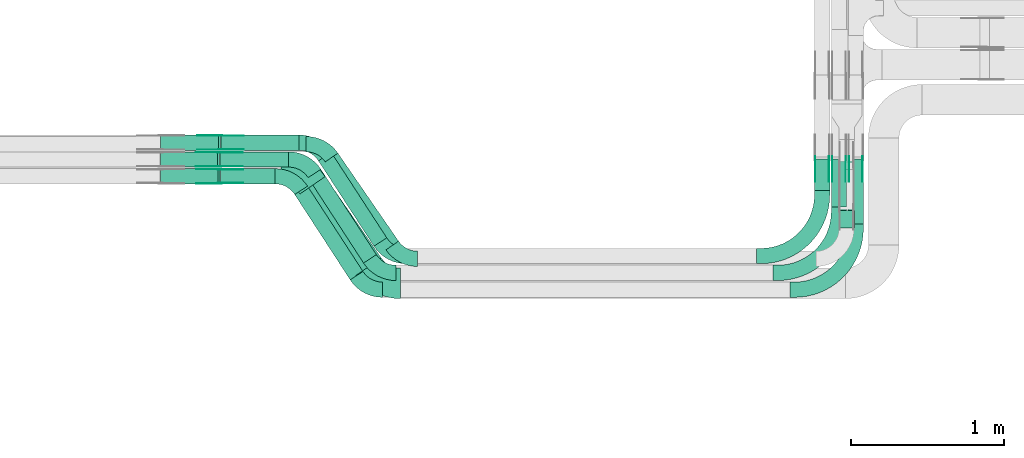
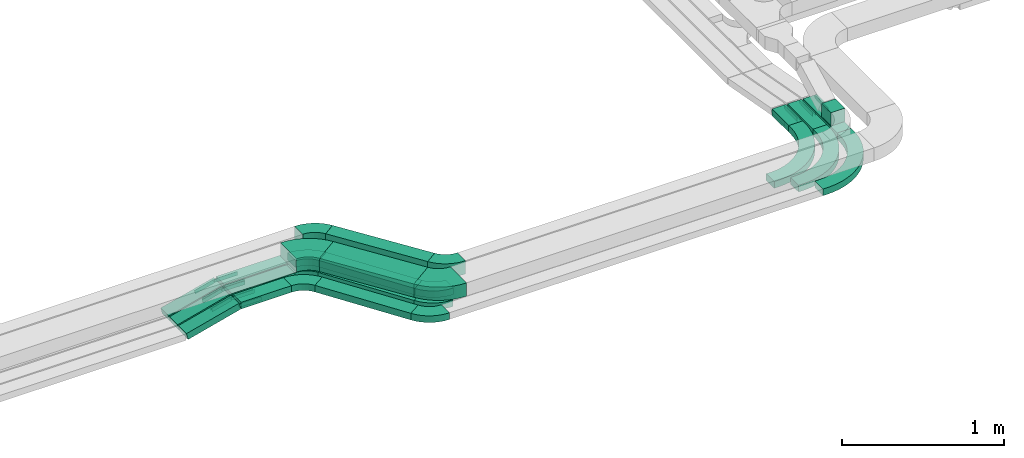
# One storey, part 9 of 25: 31 flow fittings, 15 flow segments.
"""IFC2X3 building model written with IfcOpenShell, lengths in millimetres."""

from ifc_helpers import new_model, entity, si_unit, converted_unit, derived_unit, direction, frame, frame_2d, origin, origin_2d_with_axis, place, context, subcontext, project, spatial, polyline, circle_curve, parameter, trimmed, segment, composite_curve, rectangle, outline, extrude, source, transform, mapped, material, type_object, type_shapes, element, save


model = new_model("IFC2X3")

# Units and contexts
model_context = context("Model", 3, precision=0.01, world=origin(), true_north=direction((6.12303176911189e-17, 1.0)))
body_context = subcontext(model_context, "Body", "Model", "MODEL_VIEW")
ifc_project = project(units=[si_unit("LENGTHUNIT", "METRE", prefix="MILLI"), si_unit("AREAUNIT", "SQUARE_METRE"), si_unit("VOLUMEUNIT", "CUBIC_METRE"), converted_unit("PLANEANGLEUNIT", "DEGREE", entity("IfcRatioMeasure", 0.0174532925199433), si_unit("PLANEANGLEUNIT", "RADIAN"), dimensions=[0, 0, 0, 0, 0, 0, 0]), si_unit("MASSUNIT", "GRAM", prefix="KILO"), derived_unit("MASSDENSITYUNIT", [(si_unit("MASSUNIT", "GRAM", prefix="KILO"), 1), (si_unit("LENGTHUNIT", "METRE"), -3)]), derived_unit("MOMENTOFINERTIAUNIT", [(si_unit("LENGTHUNIT", "METRE"), 4)]), si_unit("TIMEUNIT", "SECOND"), si_unit("FREQUENCYUNIT", "HERTZ"), si_unit("THERMODYNAMICTEMPERATUREUNIT", "DEGREE_CELSIUS"), derived_unit("THERMALTRANSMITTANCEUNIT", [(si_unit("MASSUNIT", "GRAM", prefix="KILO"), 1), (si_unit("THERMODYNAMICTEMPERATUREUNIT", "KELVIN"), -1), (si_unit("TIMEUNIT", "SECOND"), -3)]), derived_unit("VOLUMETRICFLOWRATEUNIT", [(si_unit("LENGTHUNIT", "METRE"), 3), (si_unit("TIMEUNIT", "SECOND"), -1)]), derived_unit("MASSFLOWRATEUNIT", [(si_unit("MASSUNIT", "GRAM", prefix="KILO"), 1), (si_unit("TIMEUNIT", "SECOND"), -1)]), derived_unit("ROTATIONALFREQUENCYUNIT", [(si_unit("TIMEUNIT", "SECOND"), -1)]), si_unit("ELECTRICCURRENTUNIT", "AMPERE"), si_unit("ELECTRICVOLTAGEUNIT", "VOLT"), si_unit("POWERUNIT", "WATT"), si_unit("FORCEUNIT", "NEWTON", prefix="KILO"), si_unit("ILLUMINANCEUNIT", "LUX"), si_unit("LUMINOUSFLUXUNIT", "LUMEN"), si_unit("LUMINOUSINTENSITYUNIT", "CANDELA"), derived_unit("USERDEFINED", [(si_unit("MASSUNIT", "GRAM", prefix="KILO"), -1), (si_unit("LENGTHUNIT", "METRE"), -2), (si_unit("TIMEUNIT", "SECOND"), 3), (si_unit("LUMINOUSFLUXUNIT", "LUMEN"), 1)]), derived_unit("LINEARVELOCITYUNIT", [(si_unit("LENGTHUNIT", "METRE"), 1), (si_unit("TIMEUNIT", "SECOND"), -1)]), si_unit("PRESSUREUNIT", "PASCAL"), derived_unit("USERDEFINED", [(si_unit("LENGTHUNIT", "METRE"), -2), (si_unit("MASSUNIT", "GRAM", prefix="KILO"), 1), (si_unit("TIMEUNIT", "SECOND"), -2)]), derived_unit("LINEARFORCEUNIT", [(si_unit("MASSUNIT", "GRAM", prefix="KILO"), 1), (si_unit("LENGTHUNIT", "METRE"), 1), (si_unit("TIMEUNIT", "SECOND"), -2), (si_unit("LENGTHUNIT", "METRE"), -1)]), derived_unit("PLANARFORCEUNIT", [(si_unit("MASSUNIT", "GRAM", prefix="KILO"), 1), (si_unit("LENGTHUNIT", "METRE"), 1), (si_unit("TIMEUNIT", "SECOND"), -2), (si_unit("LENGTHUNIT", "METRE"), -2)])], contexts=[model_context])

# Site, building, storey
site_placement = place(None, frame((0.0, -0.00077364408347762, 0.0)))
site = spatial("IfcSite", under=ifc_project, at=site_placement, CompositionType="ELEMENT")
building_placement = place(site_placement, origin())
building = spatial("IfcBuilding", under=site, at=building_placement, CompositionType="ELEMENT")
storey_placement = place(building_placement, frame((0.0, 0.0, 24000.0)))
storey = spatial("IfcBuildingStorey", under=building, at=storey_placement, CompositionType="ELEMENT", Elevation=24000.0)

# Flow segments
cable_carrier_segment_type = type_object("IfcCableCarrierSegmentType", PredefinedType="CABLETRAYSEGMENT")
flow_segment_1_placement = place(storey_placement, frame((28945.0794468743, 10007.8235639286, 2749.99997416677)))
element("IfcFlowSegment", 1, at=flow_segment_1_placement, inside=storey, type_object=cable_carrier_segment_type, context=body_context, shape_type="SweptSolid", body=[
    extrude(rectangle(XDim=449.703961054591, YDim=99.9999999999989, at=frame_2d((-2.17426077142591e-12, 0.0), x_axis=(1.0, 0.0))), frame((224.851983399546, 50.0, 1.2916621039949e-05)), (0.0, 0.0, 1.0), 49.9999999999931),
])
flow_segment_2_placement = place(storey_placement, frame((28952.8892089489, 10117.8235639283, 2749.99997093508)))
element("IfcFlowSegment", 2, at=flow_segment_2_placement, inside=storey, type_object=cable_carrier_segment_type, context=body_context, shape_type="SweptSolid", body=[
    extrude(rectangle(XDim=509.777434753036, YDim=99.9999999999989, at=frame_2d((-2.17426077142591e-12, -1.08357767203415e-12), x_axis=(1.0, 0.0))), frame((254.888720227263, 50.0, 1.45324623758825e-05)), (0.0, 0.0, 1.0), 49.9999999999974),
])
flow_segment_3_placement = place(storey_placement, frame((29589.9781757951, 9490.69919240016, 2750.0)))
element("IfcFlowSegment", 3, at=flow_segment_3_placement, inside=storey, type_object=cable_carrier_segment_type, context=body_context, shape_type="SweptSolid", body=[
    extrude(rectangle(XDim=665.559579029172, YDim=100.000000000004, at=origin_2d_with_axis()), frame((223.283289414054, 306.266508075534, 3.12262928900964e-06), z_axis=(5.11388203057767e-09, -7.86751081627487e-09, 1.0), x_axis=(0.544988350595341, -0.838443616300685, -9.38347035306593e-09)), (0.0, 0.0, 1.0), 49.9999999999973),
])
flow_segment_4_placement = place(storey_placement, frame((29634.4910697948, 9466.72606910952, 2890.0)))
element("IfcFlowSegment", 4, at=flow_segment_4_placement, inside=storey, type_object=cable_carrier_segment_type, context=body_context, shape_type="SweptSolid", body=[
    extrude(rectangle(XDim=698.971890855876, YDim=99.9999999999974, at=frame_2d((2.58637555816676e-12, 8.5265128291212e-13), x_axis=(1.0, 0.0))), frame((239.55958163975, 316.097494713159, 0.0), z_axis=(0.0, 0.0, 1.0), x_axis=(0.567682967884993, -0.823247258102501, 0.0)), (0.0, 0.0, 1.0), 100.000000000003),
])
flow_segment_5_placement = place(storey_placement, frame((28948.3109912879, 9897.82356392861, 2749.99997910151)))
element("IfcFlowSegment", 5, at=flow_segment_5_placement, inside=storey, type_object=cable_carrier_segment_type, context=body_context, shape_type="SweptSolid", body=[
    extrude(rectangle(XDim=359.081105196311, YDim=99.9999999999989, at=origin_2d_with_axis()), frame((179.540555508148, 50.0, 1.04492476452833e-05)), (0.0, 0.0, 1.0), 49.9999999999974),
])
flow_segment_6_placement = place(storey_placement, frame((29469.0115403312, 9299.95777232105, 2890.0)))
element("IfcFlowSegment", 6, at=flow_segment_6_placement, inside=storey, type_object=cable_carrier_segment_type, context=body_context, shape_type="SweptSolid", body=[
    extrude(rectangle(XDim=646.458259275562, YDim=199.999999999999, at=frame_2d((2.1316282072803e-12, 1.15818465928896e-12), x_axis=(1.0, 0.0))), frame((265.8163974299, 322.865791501663, 0.0), z_axis=(0.0, 0.0, 1.0), x_axis=(0.567682967884968, -0.823247258102519, 0.0)), (0.0, 0.0, 1.0), 100.000000000003),
])
flow_segment_7_placement = place(storey_placement, frame((29434.7036286044, 9270.69919239606, 2750.0)))
element("IfcFlowSegment", 7, at=flow_segment_7_placement, inside=storey, type_object=cable_carrier_segment_type, context=body_context, shape_type="SweptSolid", body=[
    extrude(rectangle(XDim=665.559579029205, YDim=99.9999999999987, at=frame_2d((1.90425453183707e-12, 3.93640675611096e-12), x_axis=(1.0, 0.0))), frame((223.283289414063, 306.266508083721, 3.18753634473978e-06), z_axis=(5.22016867856222e-09, -8.03102873625081e-09, 1.0), x_axis=(0.544988350595353, -0.838443616300677, -9.57849589419594e-09)), (0.0, 0.0, 1.0), 50.0000000000016),
])
flow_segment_8_placement = place(storey_placement, frame((29522.0949400319, 9380.69919239868, 2750.0)))
element("IfcFlowSegment", 8, at=flow_segment_8_placement, inside=storey, type_object=cable_carrier_segment_type, context=body_context, shape_type="SweptSolid", body=[
    extrude(rectangle(XDim=665.559579029195, YDim=99.9999999999999, at=frame_2d((9.09494701772928e-13, -5.82645043323282e-13), x_axis=(1.0, 0.0))), frame((223.283289414063, 306.266508078508, 3.14618381480614e-06), z_axis=(5.15245691573413e-09, -7.9268567934381e-09, 1.0), x_axis=(0.544988350595368, -0.838443616300667, -9.4542514718074e-09)), (0.0, 0.0, 1.0), 49.9999999999973),
])
flow_segment_9_placement = place(storey_placement, frame((28557.66472809, 9897.82356393049, 2651.99307910285)))
element("IfcFlowSegment", 9, at=flow_segment_9_placement, inside=storey, type_object=cable_carrier_segment_type, context=body_context, shape_type="SweptSolid", body=[
    extrude(rectangle(XDim=49.9999999999986, YDim=99.9999999999989, at=origin_2d_with_axis()), frame((6.29726028523068, 50.0, 24.193894124344), z_axis=(0.967755764973787, 0.0, 0.251890411409408), x_axis=(-0.251890411409408, 0.0, 0.967755764973787)), (0.0, 0.0, 1.0), 387.573437364003),
])
flow_segment_10_placement = place(storey_placement, frame((28557.6416479044, 10007.8235639291, 2652.02409303392)))
element("IfcFlowSegment", 10, at=flow_segment_10_placement, inside=storey, type_object=cable_carrier_segment_type, context=body_context, shape_type="SweptSolid", body=[
    extrude(rectangle(XDim=49.9999999999973, YDim=99.9999999999989, at=origin_2d_with_axis()), frame((6.34769694242575, 50.0, 24.1807101534848), z_axis=(0.967228406139617, 0.0, 0.253907877697044), x_axis=(-0.253907877697044, 0.0, 0.967228406139617)), (0.0, 0.0, 1.0), 384.355490296213),
])
flow_segment_11_placement = place(storey_placement, frame((28557.6970734248, 10117.8235639283, 2651.95155380425)))
element("IfcFlowSegment", 11, at=flow_segment_11_placement, inside=storey, type_object=cable_carrier_segment_type, context=body_context, shape_type="SweptSolid", body=[
    extrude(rectangle(XDim=50.0000000000031, YDim=99.9999999999989, at=origin_2d_with_axis()), frame((6.22706032243303, 50.0, 24.2120573215265), z_axis=(0.968482292861, 0.0, 0.249082412897219), x_axis=(-0.249082412897219, 0.0, 0.968482292861)), (0.0, 0.0, 1.0), 392.132317558253),
])
flow_segment_12_placement = place(storey_placement, frame((33053.0827924389, 9636.10783662939, 2750.0)))
element("IfcFlowSegment", 12, at=flow_segment_12_placement, inside=storey, type_object=cable_carrier_segment_type, context=body_context, shape_type="SweptSolid", body=[
    extrude(rectangle(XDim=426.077042321789, YDim=100.000000000003, at=frame_2d((5.40012479177676e-13, 0.0), x_axis=(1.0, 0.0))), frame((50.0, 213.038521160895, 0.0), z_axis=(0.0, 0.0, 1.0), x_axis=(0.0, -1.0, 0.0)), (0.0, 0.0, 1.0), 49.9999999999973),
])
flow_segment_13_placement = place(storey_placement, frame((32943.0827924389, 9746.1078366294, 2750.0)))
element("IfcFlowSegment", 13, at=flow_segment_13_placement, inside=storey, type_object=cable_carrier_segment_type, context=body_context, shape_type="SweptSolid", body=[
    extrude(rectangle(XDim=316.077042321782, YDim=100.000000000003, at=origin_2d_with_axis()), frame((50.0, 158.038521160892, 0.0), z_axis=(0.0, 0.0, 1.0), x_axis=(0.0, 1.0, 0.0)), (0.0, 0.0, 1.0), 49.9999999999973),
])
flow_segment_14_placement = place(storey_placement, frame((32833.0827924389, 9856.10783662938, 2750.0)))
element("IfcFlowSegment", 14, at=flow_segment_14_placement, inside=storey, type_object=cable_carrier_segment_type, context=body_context, shape_type="SweptSolid", body=[
    extrude(rectangle(XDim=206.07704232179, YDim=100.000000000003, at=frame_2d((0.0, -2.16715534406831e-12), x_axis=(1.0, 0.0))), frame((50.0, 103.038521160898, 0.0), z_axis=(0.0, 0.0, 1.0), x_axis=(0.0, -1.0, 0.0)), (0.0, 0.0, 1.0), 49.9999999999973),
])
flow_segment_15_placement = place(storey_placement, frame((32993.082792439, 9608.82356382262, 2890.0)))
element("IfcFlowSegment", 15, at=flow_segment_15_placement, inside=storey, type_object=cable_carrier_segment_type, context=body_context, shape_type="SweptSolid", body=[
    extrude(rectangle(XDim=116.82449845036, YDim=100.000000000003, at=frame_2d((5.40012479177676e-13, 2.16715534406831e-12), x_axis=(1.0, 0.0))), frame((50.0, 58.4122492252194, 0.0), z_axis=(0.0, 0.0, 1.0), x_axis=(0.0, 1.0, 0.0)), (0.0, 0.0, 1.0), 100.000000000003),
])

# Flow fittings
ifc_material_1 = material(Name="G")
cable_carrier_fitting_type_1 = type_object("IfcCableCarrierFittingType", PredefinedType="NOTDEFINED", material=ifc_material_1)
shared_shape_1 = source(origin(), body_context, "Body", "SweptSolid", [
    extrude(outline(composite_curve([segment(trimmed(circle_curve(frame_2d((-44.5901162790698, 0.0), x_axis=(1.0, 0.0)), 12.5), [parameter(90.0000000000007)], [parameter(270.0)], True, "PARAMETER"), True, "CONTINUOUS"), segment(polyline([(-44.5901162790697, -12.5), (-33.0901162790698, -12.5)]), True, "CONTINUOUS"), segment(polyline([(-33.0901162790698, -12.5), (-31.2296511627907, -14.5)]), True, "CONTINUOUS"), segment(polyline([(-31.2296511627907, -14.5), (108.90988372093, -14.5)]), True, "CONTINUOUS"), segment(polyline([(108.90988372093, -14.5), (108.90988372093, 14.5)]), True, "CONTINUOUS"), segment(polyline([(108.90988372093, 14.5), (-31.2296511627907, 14.5)]), True, "CONTINUOUS"), segment(polyline([(-31.2296511627907, 14.5), (-33.0901162790698, 12.5)]), True, "CONTINUOUS"), segment(polyline([(-33.0901162790698, 12.5), (-44.5901162790699, 12.5)]), True, "CONTINUOUS")], self_intersect=False)), frame((44.5901162790698, 0.0, 0.0), z_axis=(0.0, 0.0, -1.0), x_axis=(1.0, 0.0, 0.0)), (0.0, 0.0, -1.0), 2.0),
])
type_shapes(cable_carrier_fitting_type_1, [shared_shape_1])
for number, where, z_axis, x_axis in (
    (16, (28943.5987331358, 9902.36356392033, 2774.99997882727), (0.0, -1.0, 0.0), (-0.96775576497502, 0.0, -0.251890411404671)),
    (17, (28940.336452955, 10012.3635639189, 2774.99997389431), (0.0, -1.0, 0.0), (-0.967228406140868, 0.0, -0.253907877692276)),
    (18, (28948.2196887602, 10122.3635639181, 2774.99997066886), (0.0, -1.0, 0.0), (-0.968482292862194, 0.0, -0.249082412892576)),
):
    element("IfcFlowFitting", number, at=place(storey_placement, frame(where, z_axis=z_axis, x_axis=x_axis)), inside=storey, type_object=cable_carrier_fitting_type_1, material=ifc_material_1, context=body_context, shape_type="MappedRepresentation", body=[
        mapped(shared_shape_1, transform((0.0, 0.0, 0.0), scale=1.0)),
    ])
cable_carrier_fitting_type_2 = type_object("IfcCableCarrierFittingType", PredefinedType="NOTDEFINED", material=ifc_material_1)
shared_shape_2 = source(origin(), body_context, "Body", "SweptSolid", [
    extrude(outline(composite_curve([segment(trimmed(circle_curve(frame_2d((-44.5901162790697, 0.0), x_axis=(1.0, 0.0)), 12.5), [parameter(90.0000000000007)], [parameter(270.0)], True, "PARAMETER"), True, "CONTINUOUS"), segment(polyline([(-44.5901162790697, -12.5), (-33.0901162790697, -12.5)]), True, "CONTINUOUS"), segment(polyline([(-33.0901162790697, -12.5), (-31.2296511627907, -14.5)]), True, "CONTINUOUS"), segment(polyline([(-31.2296511627907, -14.5), (108.90988372093, -14.5)]), True, "CONTINUOUS"), segment(polyline([(108.90988372093, -14.5), (108.90988372093, 14.5)]), True, "CONTINUOUS"), segment(polyline([(108.90988372093, 14.5), (-31.2296511627907, 14.5)]), True, "CONTINUOUS"), segment(polyline([(-31.2296511627907, 14.5), (-33.0901162790698, 12.5)]), True, "CONTINUOUS"), segment(polyline([(-33.0901162790698, 12.5), (-44.5901162790699, 12.5)]), True, "CONTINUOUS")], self_intersect=False)), frame((44.5901162790697, 0.0, 0.0)), (0.0, 0.0, 1.0), 2.0),
])
type_shapes(cable_carrier_fitting_type_2, [shared_shape_2])
for number, where, z_axis, x_axis in (
    (19, (28943.5987331358, 9993.28356394065, 2774.99997882727), (0.0, 1.0, 0.0), (-0.96775576497502, 0.0, -0.251890411404671)),
    (20, (28940.336452955, 10103.2835639393, 2774.99997389431), (0.0, 1.0, 0.0), (-0.967228406140868, 0.0, -0.253907877692276)),
    (21, (28948.2196887602, 10213.2835639385, 2774.99997066886), (0.0, 1.0, 0.0), (-0.968482292862194, 0.0, -0.249082412892576)),
):
    element("IfcFlowFitting", number, at=place(storey_placement, frame(where, z_axis=z_axis, x_axis=x_axis)), inside=storey, type_object=cable_carrier_fitting_type_2, material=ifc_material_1, context=body_context, shape_type="MappedRepresentation", body=[
        mapped(shared_shape_2, transform((0.0, 0.0, 0.0), scale=1.0)),
    ])
cable_carrier_fitting_type_3 = type_object("IfcCableCarrierFittingType", PredefinedType="NOTDEFINED", material=ifc_material_1)
shared_shape_3 = source(origin(), body_context, "Body", "SweptSolid", [
    extrude(outline(composite_curve([segment(trimmed(circle_curve(frame_2d((-44.5901162790698, 0.0), x_axis=(1.0, 0.0)), 12.5), [parameter(90.0000000000007)], [parameter(270.0)], True, "PARAMETER"), True, "CONTINUOUS"), segment(polyline([(-44.5901162790697, -12.5), (-33.0901162790698, -12.5)]), True, "CONTINUOUS"), segment(polyline([(-33.0901162790698, -12.5), (-31.2296511627907, -14.5)]), True, "CONTINUOUS"), segment(polyline([(-31.2296511627907, -14.5), (108.90988372093, -14.5)]), True, "CONTINUOUS"), segment(polyline([(108.90988372093, -14.5), (108.90988372093, 14.5)]), True, "CONTINUOUS"), segment(polyline([(108.90988372093, 14.5), (-31.2296511627907, 14.5)]), True, "CONTINUOUS"), segment(polyline([(-31.2296511627907, 14.5), (-33.0901162790698, 12.5)]), True, "CONTINUOUS"), segment(polyline([(-33.0901162790698, 12.5), (-44.5901162790699, 12.5)]), True, "CONTINUOUS")], self_intersect=False)), frame((44.5901162790698, 0.0, 0.0), z_axis=(0.0, 0.0, -1.0), x_axis=(1.0, 0.0, 0.0)), (0.0, 0.0, -1.0), 2.0),
])
type_shapes(cable_carrier_fitting_type_3, [shared_shape_3])
for number, where, z_axis, x_axis in (
    (22, (28943.5987331358, 9991.28356394065, 2774.99997882726), (0.0, 1.0, 0.0), (1.0, 0.0, 5.81999550691969e-08)),
    (23, (28940.336452955, 10101.2835639393, 2774.99997389431), (0.0, 1.0, 0.0), (1.0, 0.0, 5.74450136485811e-08)),
    (24, (28948.2196887602, 10211.2835639385, 2774.99997066885), (0.0, 1.0, 0.0), (1.0, 0.0, 5.70149555300472e-08)),
    (25, (32926.542792449, 10065.8378366345, 2775.0), (1.0, 0.0, 0.0), (0.0, -1.0, 0.0)),
    (26, (33036.542792449, 10065.8378366345, 2775.0), (1.0, 0.0, 0.0), (0.0, -1.0, 0.0)),
    (27, (33146.542792449, 10065.8378366345, 2775.0), (1.0, 0.0, 0.0), (0.0, -1.0, 0.0)),
):
    element("IfcFlowFitting", number, at=place(storey_placement, frame(where, z_axis=z_axis, x_axis=x_axis)), inside=storey, type_object=cable_carrier_fitting_type_3, material=ifc_material_1, context=body_context, shape_type="MappedRepresentation", body=[
        mapped(shared_shape_3, transform((0.0, 0.0, 0.0), scale=1.0)),
    ])
cable_carrier_fitting_type_4 = type_object("IfcCableCarrierFittingType", PredefinedType="NOTDEFINED", material=ifc_material_1)
shared_shape_4 = source(origin(), body_context, "Body", "SweptSolid", [
    extrude(outline(composite_curve([segment(trimmed(circle_curve(frame_2d((-44.5901162790697, 0.0), x_axis=(1.0, 0.0)), 12.5), [parameter(90.0000000000007)], [parameter(270.0)], True, "PARAMETER"), True, "CONTINUOUS"), segment(polyline([(-44.5901162790697, -12.5), (-33.0901162790697, -12.5)]), True, "CONTINUOUS"), segment(polyline([(-33.0901162790697, -12.5), (-31.2296511627907, -14.5)]), True, "CONTINUOUS"), segment(polyline([(-31.2296511627907, -14.5), (108.90988372093, -14.5)]), True, "CONTINUOUS"), segment(polyline([(108.90988372093, -14.5), (108.90988372093, 14.5)]), True, "CONTINUOUS"), segment(polyline([(108.90988372093, 14.5), (-31.2296511627907, 14.5)]), True, "CONTINUOUS"), segment(polyline([(-31.2296511627907, 14.5), (-33.0901162790698, 12.5)]), True, "CONTINUOUS"), segment(polyline([(-33.0901162790698, 12.5), (-44.5901162790699, 12.5)]), True, "CONTINUOUS")], self_intersect=False)), frame((44.5901162790697, 0.0, 0.0)), (0.0, 0.0, 1.0), 2.0),
])
type_shapes(cable_carrier_fitting_type_4, [shared_shape_4])
for number, where, z_axis, x_axis in (
    (28, (28943.5987331358, 9904.36356392034, 2774.99997882726), (0.0, -1.0, 0.0), (1.0, 0.0, 5.81999550691969e-08)),
    (29, (28940.336452955, 10014.3635639189, 2774.99997389431), (0.0, -1.0, 0.0), (1.0, 0.0, 5.74450136485811e-08)),
    (30, (28948.2196887602, 10124.3635639181, 2774.99997066885), (0.0, -1.0, 0.0), (1.0, 0.0, 5.70149555300472e-08)),
    (31, (32839.6227924287, 10065.8378366345, 2775.0), (-1.0, 0.0, 0.0), (0.0, -1.0, 0.0)),
    (32, (32949.6227924287, 10065.8378366345, 2775.0), (-1.0, 0.0, 0.0), (0.0, -1.0, 0.0)),
    (33, (33059.6227924287, 10065.8378366345, 2775.0), (-1.0, 0.0, 0.0), (0.0, -1.0, 0.0)),
):
    element("IfcFlowFitting", number, at=place(storey_placement, frame(where, z_axis=z_axis, x_axis=x_axis)), inside=storey, type_object=cable_carrier_fitting_type_4, material=ifc_material_1, context=body_context, shape_type="MappedRepresentation", body=[
        mapped(shared_shape_4, transform((0.0, 0.0, 0.0), scale=1.0)),
    ])
ifc_material_2 = material()
cable_carrier_fitting_type_5 = type_object("IfcCableCarrierFittingType", Name="470_DKC_S5_Variable Angle Elbow 0-45:-", PredefinedType="NOTDEFINED", material=ifc_material_2)
shared_shape_5 = source(origin(), body_context, "Body", "SweptSolid", [
    extrude(outline(composite_curve([segment(polyline([(-83.216646552221, -93.4375150260266), (-82.2166465522198, -93.4375150260266)]), True, "CONTINUOUS"), segment(trimmed(circle_curve(frame_2d((-82.2166465522222, 156.562484973973), x_axis=(0.0, -1.0)), 250.0), [parameter(0.0)], [parameter(55.4111904090834)], True, "PARAMETER"), True, "CONTINUOUS"), segment(polyline([(123.595167973403, 14.6417430027258), (124.162850941288, 15.464990260828)]), True, "CONTINUOUS"), segment(polyline([(124.162850941288, 15.464990260828), (41.8381251310381, 72.2332870493274)]), True, "CONTINUOUS"), segment(polyline([(41.8381251310381, 72.2332870493274), (41.270442163153, 71.4100397912247)]), True, "CONTINUOUS"), segment(trimmed(circle_curve(frame_2d((-82.2166465522222, 156.562484973973), x_axis=(0.0, -1.0)), 150.0), [parameter(0.0)], [parameter(55.4111904090834)], True, "PARAMETER"), False, "CONTINUOUS"), segment(polyline([(-82.2166465522206, 6.56248497397328), (-83.2166465522218, 6.56248497397327)]), True, "CONTINUOUS"), segment(polyline([(-83.2166465522218, 6.56248497397327), (-83.216646552221, -93.4375150260266)]), True, "CONTINUOUS")], self_intersect=False)), frame((-22.8106166084022, 43.4375150260178, -50.0)), (0.0, 0.0, 1.0), 100.0),
])
type_shapes(cable_carrier_fitting_type_5, [shared_shape_5])
for number, where, z_axis, x_axis, name in (
    (34, (29615.4635612721, 10157.8235638227, 2940.0), (0.0, 0.0, 1.0), (-0.567682967884992, 0.823247258102502, 0.0), "470_DKC_S5_Variable Angle Elbow 0-45:-"),
    (35, (30132.6377415969, 9407.82356382268, 2940.0), (0.0, 0.0, 1.0), (0.567682967884987, -0.823247258102505, 0.0), "470_DKC_S5_Variable Angle Elbow 0-45:-"),
):
    element("IfcFlowFitting", number, at=place(storey_placement, frame(where, z_axis=z_axis, x_axis=x_axis)), inside=storey, type_object=cable_carrier_fitting_type_5, material=ifc_material_2, Name=name, ObjectType="470_DKC_S5_Variable Angle Elbow 0-45:-", context=body_context, shape_type="MappedRepresentation", body=[
        mapped(shared_shape_5, transform((0.0, 0.0, 0.0), scale=1.0)),
    ])
cable_carrier_fitting_type_6 = type_object("IfcCableCarrierFittingType", Name="470_DKC_S5_Variable Angle Elbow 0-45:-", PredefinedType="NOTDEFINED", material=ifc_material_2)
shared_shape_6 = source(origin(), body_context, "Body", "SweptSolid", [
    extrude(outline(composite_curve([segment(polyline([(-103.797828004785, -154.245440828902), (-102.797828004784, -154.245440828902)]), True, "CONTINUOUS"), segment(trimmed(circle_curve(frame_2d((-102.797828004784, 195.754559171098), x_axis=(0.0, -1.0)), 350.0), [parameter(0.0)], [parameter(55.411190409084)], True, "PARAMETER"), True, "CONTINUOUS"), segment(polyline([(185.338712331092, -2.93447958864822), (185.906395298976, -2.11123233054757)]), True, "CONTINUOUS"), segment(polyline([(185.906395298976, -2.11123233054764), (21.2569436784775, 111.425361246454)]), True, "CONTINUOUS"), segment(polyline([(21.2569436784775, 111.425361246454), (20.6892607105913, 110.60211398835)]), True, "CONTINUOUS"), segment(trimmed(circle_curve(frame_2d((-102.797828004784, 195.754559171098), x_axis=(0.0, -1.0)), 150.0), [parameter(0.0)], [parameter(55.411190409084)], True, "PARAMETER"), False, "CONTINUOUS"), segment(polyline([(-102.797828004784, 45.7545591710979), (-103.797828004785, 45.7545591710979)]), True, "CONTINUOUS"), segment(polyline([(-103.797828004785, 45.7545591710979), (-103.797828004785, -154.245440828902)]), True, "CONTINUOUS")], self_intersect=False)), frame((-28.4862509459988, 54.2454408288939, -50.0)), (0.0, 0.0, 1.0), 100.0),
])
type_shapes(cable_carrier_fitting_type_6, [shared_shape_6])
for number, where, z_axis, x_axis, name in (
    (36, (29476.2408475987, 9997.82356382271, 2940.0), (0.0, 0.0, 1.0), (-0.56768296788499, 0.823247258102503, 0.0), "470_DKC_S5_Variable Angle Elbow 0-45:-"),
    (37, (29993.4150279234, 9247.8235638227, 2940.0), (0.0, 0.0, 1.0), (0.567682967884968, -0.823247258102519, 0.0), "470_DKC_S5_Variable Angle Elbow 0-45:-"),
):
    element("IfcFlowFitting", number, at=place(storey_placement, frame(where, z_axis=z_axis, x_axis=x_axis)), inside=storey, type_object=cable_carrier_fitting_type_6, material=ifc_material_2, Name=name, ObjectType="470_DKC_S5_Variable Angle Elbow 0-45:-", context=body_context, shape_type="MappedRepresentation", body=[
        mapped(shared_shape_6, transform((0.0, 0.0, 0.0), scale=1.0)),
    ])
cable_carrier_fitting_type_7 = type_object("IfcCableCarrierFittingType", Name="470_DKC_S5_Variable Angle Elbow 0-45:-", PredefinedType="NOTDEFINED", material=ifc_material_2)
shared_shape_7 = source(origin(), body_context, "Body", "SweptSolid", [
    extrude(outline(composite_curve([segment(polyline([(-84.7306087177134, -95.7107758445339), (-83.7306087177122, -95.7107758445339)]), True, "CONTINUOUS"), segment(trimmed(circle_curve(frame_2d((-83.7306087177125, 154.289224155466), x_axis=(0.0, -1.0)), 250.0), [parameter(0.0)], [parameter(56.9761324442035)], True, "PARAMETER"), True, "CONTINUOUS"), segment(polyline([(125.880295357447, 18.0421365066129), (126.425283708042, 18.8805801229131)]), True, "CONTINUOUS"), segment(polyline([(126.425283708042, 18.8805801229131), (42.5809220779788, 73.3794151824551)]), True, "CONTINUOUS"), segment(polyline([(42.5809220779787, 73.3794151824551), (42.035933727383, 72.5409715661541)]), True, "CONTINUOUS"), segment(trimmed(circle_curve(frame_2d((-83.7306087177125, 154.289224155466), x_axis=(0.0, -1.0)), 150.0), [parameter(0.0)], [parameter(56.9761324442035)], True, "PARAMETER"), False, "CONTINUOUS"), segment(polyline([(-83.7306087177122, 4.28922415546593), (-84.7306087177134, 4.28922415546593)]), True, "CONTINUOUS"), segment(polyline([(-84.7306087177134, 4.28922415546593), (-84.7306087177134, -95.7107758445339)]), True, "CONTINUOUS")], self_intersect=False)), frame((-24.8066001198093, 45.7107758445259, -25.0)), (0.0, 0.0, 1.0), 49.9999999999998),
])
type_shapes(cable_carrier_fitting_type_7, [shared_shape_7])
for number, where, z_axis, x_axis, name in (
    (38, (29572.2038539648, 10167.8235639286, 2775.00000624526), (-5.70149492850431e-08, -3.70597170352731e-08, 1.0), (-0.544988350595363, 0.83844361630067, 0.0), "470_DKC_S5_Variable Angle Elbow 0-45:-"),
    (39, (29504.3206182025, 10057.8235639286, 2775.00000629237), (-5.74450074035765e-08, -3.73392548123228e-08, 1.0), (-0.544988350595394, 0.83844361630065, 0.0), "470_DKC_S5_Variable Angle Elbow 0-45:-"),
    (40, (29416.9293067767, 9947.8235639286, 2775.00000637506), (-5.81999488241923e-08, -3.78299667357214e-08, 1.0), (-0.544988350595377, 0.838443616300661, 0.0), "470_DKC_S5_Variable Angle Elbow 0-45:-"),
    (41, (30054.3190767092, 9426.1078366294, 2775.0), (0.0, 0.0, 1.0), (0.544988350595342, -0.838443616300684, 0.0), "470_DKC_S5_Variable Angle Elbow 0-45:-"),
    (42, (29986.435840947, 9316.1078366294, 2775.0), (0.0, 0.0, 1.0), (0.544988350595373, -0.838443616300664, 0.0), "470_DKC_S5_Variable Angle Elbow 0-45:-"),
    (43, (29899.0445295211, 9206.10783662939, 2775.0), (0.0, 0.0, 1.0), (0.544988350595354, -0.838443616300676, 0.0), "470_DKC_S5_Variable Angle Elbow 0-45:-"),
):
    element("IfcFlowFitting", number, at=place(storey_placement, frame(where, z_axis=z_axis, x_axis=x_axis)), inside=storey, type_object=cable_carrier_fitting_type_7, material=ifc_material_2, Name=name, ObjectType="470_DKC_S5_Variable Angle Elbow 0-45:-", context=body_context, shape_type="MappedRepresentation", body=[
        mapped(shared_shape_7, transform((0.0, 0.0, 0.0), scale=1.0)),
    ])
cable_carrier_fitting_type_8 = type_object("IfcCableCarrierFittingType", Name="470_DKC_S5_CPO 45 horizontal angle:-", PredefinedType="NOTDEFINED", material=ifc_material_2)
shared_shape_8 = source(origin(), body_context, "Body", "SweptSolid", [
    extrude(outline(composite_curve([segment(polyline([(-222.5, -257.5), (-192.5, -257.5)]), True, "CONTINUOUS"), segment(trimmed(circle_curve(frame_2d((-192.5, 192.5), x_axis=(0.0, -1.0)), 450.0), [parameter(0.0)], [parameter(90.0)], True, "PARAMETER"), True, "CONTINUOUS"), segment(polyline([(257.5, 192.5), (257.5, 222.5)]), True, "CONTINUOUS"), segment(polyline([(257.5, 222.5), (157.5, 222.5)]), True, "CONTINUOUS"), segment(polyline([(157.5, 222.5), (157.5, 192.5)]), True, "CONTINUOUS"), segment(trimmed(circle_curve(frame_2d((-192.5, 192.5), x_axis=(0.0, -1.0)), 350.0), [parameter(0.0)], [parameter(90.0)], True, "PARAMETER"), False, "CONTINUOUS"), segment(polyline([(-192.5, -157.5), (-222.5, -157.5)]), True, "CONTINUOUS"), segment(polyline([(-222.5, -157.5), (-222.5, -257.5)]), True, "CONTINUOUS")], self_intersect=False)), frame((-207.499999999991, 207.499999999992, -25.0)), (0.0, 0.0, 1.0), 50.0000000000002),
])
type_shapes(cable_carrier_fitting_type_8, [shared_shape_8])
for number, where, name in (
    (44, (32883.0827924389, 9426.1078366294, 2775.0), "470_DKC_S5_45 horizontal angle"),
    (45, (32993.0827924389, 9316.10783662941, 2775.0), "470_DKC_S5_45 horizontal angle"),
    (46, (33103.0827924389, 9206.10783662941, 2775.0), "470_DKC_S5_45 horizontal angle"),
):
    element("IfcFlowFitting", number, at=place(storey_placement, frame(where)), inside=storey, type_object=cable_carrier_fitting_type_8, material=ifc_material_2, Name=name, ObjectType="470_DKC_S5_CPO 45 horizontal angle:-", context=body_context, shape_type="MappedRepresentation", body=[
        mapped(shared_shape_8, transform((0.0, 0.0, 0.0), scale=1.0)),
    ])

save(model, "model.ifc")
